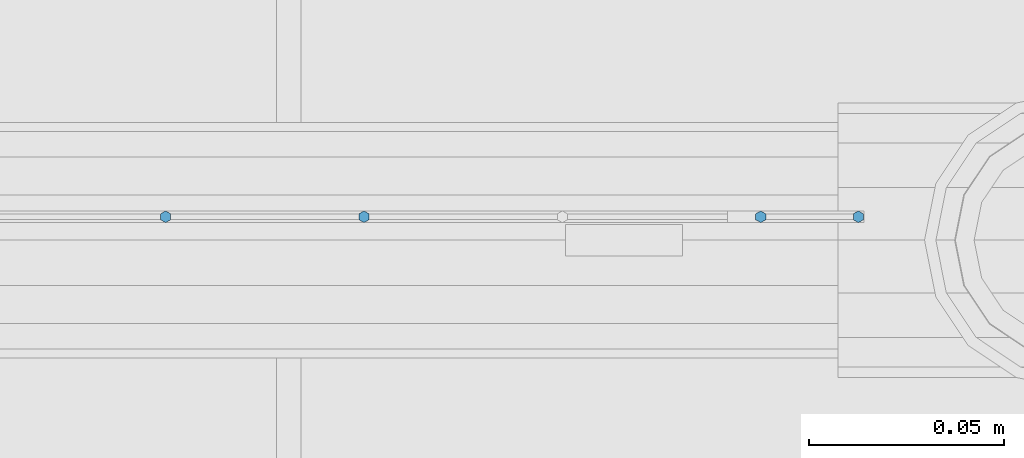
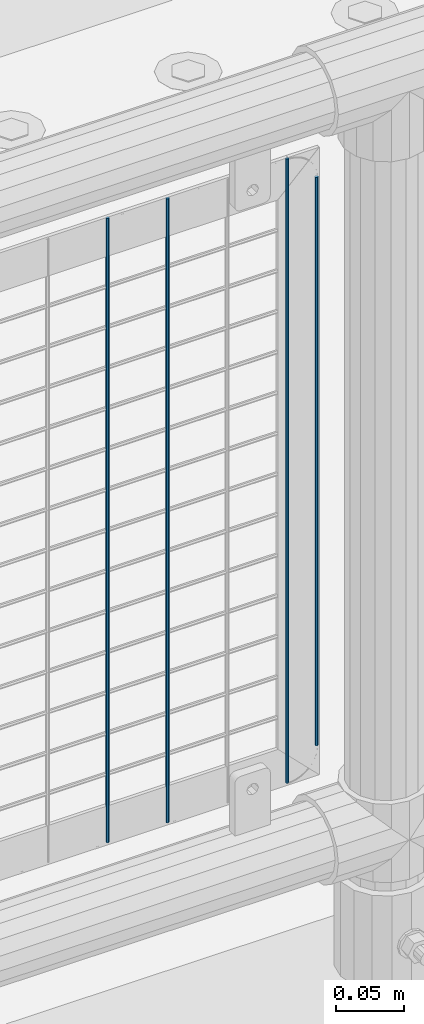
# One storey, part 72 of 270: 4 columns.
"""IFC2X3 building model written with IfcOpenShell, lengths in millimetres."""

from ifc_helpers import new_model, si_unit, frame, origin_with_axes, place, context, subcontext, project, spatial, faceted_brep, material, type_object, element, save


model = new_model("IFC2X3")

# Units and contexts
model_context = context("Model", 3, precision=1e-05, world=origin_with_axes())
body_context = subcontext(model_context, "Body", "Model", "MODEL_VIEW")
ifc_project = project(units=[si_unit("LENGTHUNIT", "METRE", prefix="MILLI"), si_unit("AREAUNIT", "SQUARE_METRE"), si_unit("VOLUMEUNIT", "CUBIC_METRE"), si_unit("MASSUNIT", "GRAM", prefix="KILO"), si_unit("TIMEUNIT", "SECOND"), si_unit("PLANEANGLEUNIT", "RADIAN"), si_unit("SOLIDANGLEUNIT", "STERADIAN"), si_unit("THERMODYNAMICTEMPERATUREUNIT", "DEGREE_CELSIUS"), si_unit("LUMINOUSINTENSITYUNIT", "LUMEN")], contexts=[model_context])

# Site, building, storey
site_placement = place(None, origin_with_axes())
site = spatial("IfcSite", under=ifc_project, at=site_placement, CompositionType="ELEMENT")
building_placement = place(site_placement, origin_with_axes())
building = spatial("IfcBuilding", under=site, at=building_placement, Name="Standard", CompositionType="ELEMENT")
storey_placement = place(building_placement, origin_with_axes())
storey = spatial("IfcBuildingStorey", under=building, at=storey_placement, Name="Undefined", CompositionType="ELEMENT", Elevation=0.0)

# Columns
ifc_material = material(Name="Misc_Undefined")
column_type = type_object("IfcColumnType", Name="D3", PredefinedType="NOTDEFINED")
for number, where, z_axis, x_axis in (
    (1, (2072.411, -16329.5, 353.02), (-1.0, 0.0, 0.0), (0.0, 0.0, 1.0)),
    (2, (2021.618, -16329.5, 353.02), (-1.0, 0.0, 0.0), (0.0, 0.0, 1.0)),
    (3, (2173.997, -16329.5, 353.02), (-1.0, 0.0, 0.0), (0.0, 0.0, 1.0)),
):
    element("IfcColumn", number, at=place(storey_placement, frame(where, z_axis=z_axis, x_axis=x_axis)), inside=storey, type_object=column_type, material=ifc_material, ObjectType="D3", context=body_context, shape_type="Brep", body=[
        faceted_brep([(0.0, -1.5, 0.0), (0.0, -0.75, -1.29903810567669), (560.0, -0.75, -1.29903810567703), (560.0, -1.5, 0.0), (0.0, 0.75, -1.29903810567669), (560.0, 0.75, -1.29903810567703), (0.0, 1.5, 0.0), (560.0, 1.5, 0.0), (0.0, 0.75, 1.29903810567669), (560.0, 0.75, 1.29903810567703), (0.0, -0.75, 1.29903810567669), (560.0, -0.75, 1.29903810567703)], [[[0, 1, 2, 3]], [[1, 4, 5, 2]], [[4, 6, 7, 5]], [[6, 8, 9, 7]], [[8, 10, 11, 9]], [[10, 0, 3, 11]], [[5, 7, 9, 11, 3, 2]], [[10, 8, 6, 4, 1, 0]]]),
    ])
column_placement = place(storey_placement, frame((2199.0, -16329.5, 378.02), z_axis=(-1.0, 0.0, 0.0), x_axis=(0.0, 0.0, 1.0)))
element("IfcColumn", 4, at=column_placement, inside=storey, type_object=column_type, material=ifc_material, ObjectType="D3", context=body_context, shape_type="Brep", body=[
    faceted_brep([(0.0, -1.5, 0.0), (0.0, -0.75, -1.29903810567669), (510.0, -0.75, -1.29903810567703), (510.0, -1.5, 0.0), (0.0, 0.75, -1.29903810567669), (510.0, 0.75, -1.29903810567703), (0.0, 1.5, 0.0), (510.0, 1.5, 0.0), (0.0, 0.75, 1.29903810567669), (510.0, 0.75, 1.29903810567703), (0.0, -0.75, 1.29903810567669), (510.0, -0.75, 1.29903810567703)], [[[0, 1, 2, 3]], [[1, 4, 5, 2]], [[4, 6, 7, 5]], [[6, 8, 9, 7]], [[8, 10, 11, 9]], [[10, 0, 3, 11]], [[5, 7, 9, 11, 3, 2]], [[10, 8, 6, 4, 1, 0]]]),
])

save(model, "model.ifc")
